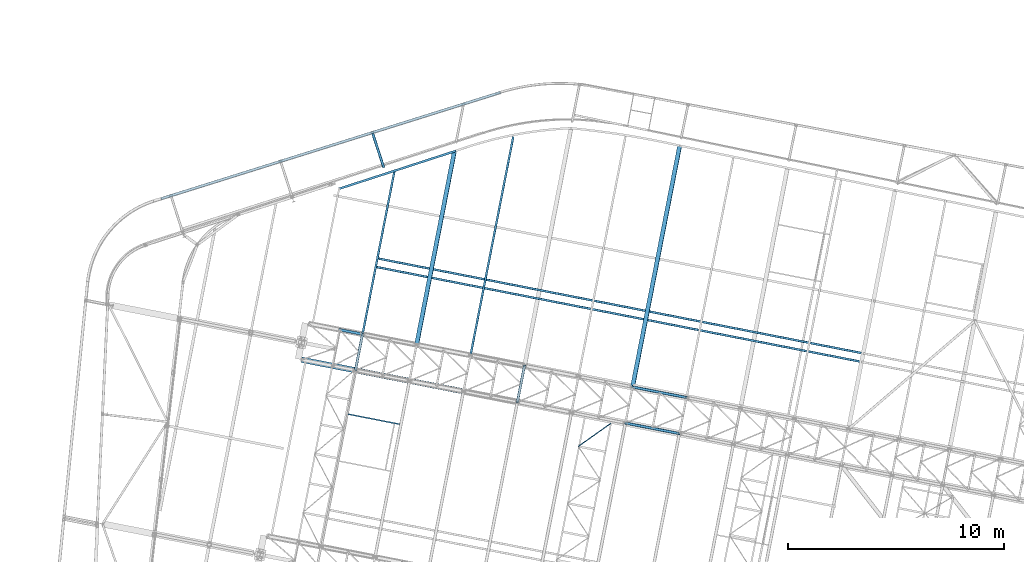
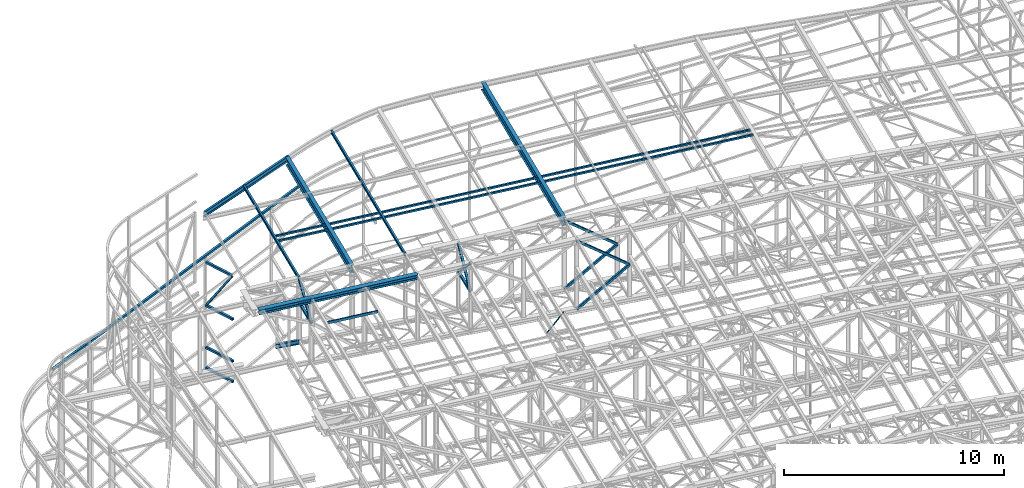
# One storey, part 85 of 215: 18 beams, 9 members, 27 elements without a shape of their own.
"""IFC2X3 building model written with IfcOpenShell, lengths in millimetres."""

from ifc_helpers import new_model, si_unit, frame, origin_with_axes, origin_2d_with_axis, place, context, subcontext, project, spatial, hollow_rectangle, i_section, u_section, extrude, clip, halfspace, material, type_object, element, aggregate, save


model = new_model("IFC2X3")

# Units and contexts
model_context = context("Model", 3, precision=1e-05, world=origin_with_axes())
body_context = subcontext(model_context, "Body", "Model", "MODEL_VIEW")
ifc_project = project(units=[si_unit("LENGTHUNIT", "METRE", prefix="MILLI"), si_unit("AREAUNIT", "SQUARE_METRE"), si_unit("VOLUMEUNIT", "CUBIC_METRE"), si_unit("MASSUNIT", "GRAM", prefix="KILO"), si_unit("TIMEUNIT", "SECOND"), si_unit("PLANEANGLEUNIT", "RADIAN"), si_unit("SOLIDANGLEUNIT", "STERADIAN"), si_unit("THERMODYNAMICTEMPERATUREUNIT", "DEGREE_CELSIUS"), si_unit("LUMINOUSINTENSITYUNIT", "LUMEN")], contexts=[model_context])

# Site, building, storey
site_placement = place(None, origin_with_axes())
site = spatial("IfcSite", under=ifc_project, at=site_placement, CompositionType="ELEMENT")
building_placement = place(site_placement, origin_with_axes())
building = spatial("IfcBuilding", under=site, at=building_placement, Name="Undefined", CompositionType="ELEMENT")
storey_placement = place(building_placement, origin_with_axes())
storey = spatial("IfcBuildingStorey", under=building, at=storey_placement, Name="Undefined", CompositionType="ELEMENT", Elevation=0.0)

# Assembly, beam
assembly_1_placement = place(storey_placement, origin_with_axes())
assembly_1 = element("IfcElementAssembly", 1, at=assembly_1_placement, inside=storey, Name="Steel Assembly", AssemblyPlace="NOTDEFINED", PredefinedType="RIGID_FRAME")
ifc_material_1 = material(Name="STEEL/S355JR")
beam_type_1 = type_object("IfcBeamType", Name="IPE240", PredefinedType="NOTDEFINED")
beam_1_placement = place(assembly_1_placement, frame((49720.9342823001, 53220.8282778538, 8620.00000002625), z_axis=(0.0, 0.0, 1.0), x_axis=(0.981422409205525, -0.19185946604018, 1.89999991602007e-08)))
beam_1 = element("IfcBeam", 2, at=beam_1_placement, type_object=beam_type_1, material=ifc_material_1, ObjectType="IPE240", context=body_context, shape_type="SweptSolid", body=[
    extrude(i_section(OverallWidth=120.0, OverallDepth=240.0, WebThickness=6.199999809, FlangeThickness=9.800000191, FilletRadius=15.0, at=origin_2d_with_axis()), frame((1125.93643654122, 0.0, 0.0), z_axis=(-1.0, 0.0, 0.0), x_axis=(-6.93889390390723e-18, -1.0, -3.46944695195361e-18)), (0.0, 0.0, 1.0), 1125.9),
])
aggregate(assembly_1, [beam_1])

assembly_2_placement = place(storey_placement, origin_with_axes())
assembly_2 = element("IfcElementAssembly", 3, at=assembly_2_placement, inside=storey, Name="Steel Assembly", AssemblyPlace="NOTDEFINED", PredefinedType="RIGID_FRAME")
ifc_material_2 = material(Name="STEEL/S275JR")
beam_type_2 = type_object("IfcBeamType", PredefinedType="NOTDEFINED")
beam_2_placement = place(assembly_2_placement, frame((57199.7178699806, 64183.9594944319, 8168.21947642145), z_axis=(-0.298921317164978, 0.954277761526672, 0.0), x_axis=(-0.949616807659648, -0.297461303893387, -0.0987152029646195)))
beam_2 = element("IfcBeam", 4, at=beam_2_placement, type_object=beam_type_2, material=ifc_material_2, Name="LISSE", context=body_context, shape_type="SweptSolid", body=[
    extrude(hollow_rectangle(XDim=120.0, YDim=120.0, WallThickness=4.0, InnerFilletRadius=4.0, OuterFilletRadius=8.0, at=origin_2d_with_axis()), frame((16520.13991497, -1.81898940354586e-12, 8.22106959654023e-12), z_axis=(-1.0, 0.0, 0.0), x_axis=(-6.93889390390723e-18, -1.0, -3.46944695195361e-18)), (0.0, 0.0, 1.0), 16520.1),
])
aggregate(assembly_2, [beam_2])

assembly_3_placement = place(storey_placement, origin_with_axes())
assembly_3 = element("IfcElementAssembly", 5, at=assembly_3_placement, inside=storey, Name="Steel Assembly", AssemblyPlace="NOTDEFINED", PredefinedType="RIGID_FRAME")
beam_type_3 = type_object("IfcBeamType", PredefinedType="NOTDEFINED")
beam_3_placement = place(assembly_3_placement, frame((50499.7937348464, 51336.3886035266, 10796.0000010378), z_axis=(0.981422364268518, -0.191859461052493, -0.000300197000082615), x_axis=(0.191859470081235, 0.981422408415534, 0.0)))
beam_3 = element("IfcBeam", 6, at=beam_3_placement, type_object=beam_type_3, material=ifc_material_2, context=body_context, shape_type="SweptSolid", body=[
    extrude(hollow_rectangle(XDim=120.0, YDim=120.0, WallThickness=5.0, InnerFilletRadius=5.0, OuterFilletRadius=10.0, at=origin_2d_with_axis()), frame((1699.99999941724, 1.81898940354586e-12, 0.0), z_axis=(-1.0, 0.0, 0.0), x_axis=(-6.93889390390723e-18, -1.0, -3.46944695195361e-18)), (0.0, 0.0, 1.0), 1700.0),
])
aggregate(assembly_3, [beam_3])

assembly_4_placement = place(storey_placement, origin_with_axes())
assembly_4 = element("IfcElementAssembly", 7, at=assembly_4_placement, inside=storey, Name="Steel Assembly", AssemblyPlace="NOTDEFINED", PredefinedType="RIGID_FRAME")
beam_4_placement = place(assembly_4_placement, frame((57988.3019099804, 49872.4511087156, 10796.0000010585), z_axis=(0.981422364268518, -0.191859461052493, -0.000300197000082615), x_axis=(0.191859470081235, 0.981422408415534, 0.0)))
beam_4 = element("IfcBeam", 8, at=beam_4_placement, type_object=beam_type_3, material=ifc_material_2, context=body_context, shape_type="SweptSolid", body=[
    extrude(hollow_rectangle(XDim=120.0, YDim=120.0, WallThickness=5.0, InnerFilletRadius=5.0, OuterFilletRadius=10.0, at=origin_2d_with_axis()), frame((1699.99999941724, 1.81898940354586e-12, 0.0), z_axis=(-1.0, 0.0, 0.0), x_axis=(-6.93889390390723e-18, -1.0, -3.46944695195361e-18)), (0.0, 0.0, 1.0), 1700.0),
])
aggregate(assembly_4, [beam_4])

assembly_5_placement = place(storey_placement, origin_with_axes())
assembly_5 = element("IfcElementAssembly", 9, at=assembly_5_placement, inside=storey, Name="Steel Assembly", AssemblyPlace="NOTDEFINED", PredefinedType="RIGID_FRAME")
beam_5_placement = place(assembly_5_placement, frame((51302.0859467722, 62273.9068351833, 4846.36704267052), z_axis=(-0.951354549825319, -0.308098231943425, 0.0), x_axis=(0.30809823194343, -0.951354549825318, -1.99999977269e-09)))
beam_5 = element("IfcBeam", 10, at=beam_5_placement, type_object=beam_type_3, material=ifc_material_2, context=body_context, shape_type="SweptSolid", body=[
    extrude(hollow_rectangle(XDim=120.0, YDim=120.0, WallThickness=5.0, InnerFilletRadius=5.0, OuterFilletRadius=10.0, at=origin_2d_with_axis()), frame((1647.01960404761, -9.09494701091737e-13, 3.50813501506244e-29), z_axis=(-1.0, 0.0, 0.0), x_axis=(-6.93889390390723e-18, -1.0, -3.46944695195361e-18)), (0.0, 0.0, 1.0), 1647.0),
])
aggregate(assembly_5, [beam_5])

assembly_6_placement = place(storey_placement, origin_with_axes())
assembly_6 = element("IfcElementAssembly", 11, at=assembly_6_placement, inside=storey, Name="Steel Assembly", AssemblyPlace="NOTDEFINED", PredefinedType="RIGID_FRAME")
beam_6_placement = place(assembly_6_placement, frame((51302.0851895902, 62273.9066010816, 1388.24312905924), z_axis=(-0.951354549825319, -0.308098231943425, 0.0), x_axis=(0.30809823194343, -0.951354549825318, -1.99999977269e-09)))
beam_6 = element("IfcBeam", 12, at=beam_6_placement, type_object=beam_type_3, material=ifc_material_2, context=body_context, shape_type="SweptSolid", body=[
    extrude(hollow_rectangle(XDim=120.0, YDim=120.0, WallThickness=5.0, InnerFilletRadius=5.0, OuterFilletRadius=10.0, at=origin_2d_with_axis()), frame((1647.01960404761, -9.09494701091737e-13, 3.50813501506244e-29), z_axis=(-1.0, 0.0, 0.0), x_axis=(-6.93889390390723e-18, -1.0, -3.46944695195361e-18)), (0.0, 0.0, 1.0), 1647.0),
])
aggregate(assembly_6, [beam_6])

assembly_7_placement = place(storey_placement, origin_with_axes())
assembly_7 = element("IfcElementAssembly", 13, at=assembly_7_placement, inside=storey, Name="Steel Assembly", AssemblyPlace="NOTDEFINED", PredefinedType="RIGID_FRAME")
beam_7_placement = place(assembly_7_placement, frame((51302.0859461039, 62273.9068372421, 2522.06977230949), z_axis=(-0.951354549825319, -0.308098231943425, 0.0), x_axis=(0.30809823194343, -0.951354549825318, -1.99999977269e-09)))
beam_7 = element("IfcBeam", 14, at=beam_7_placement, type_object=beam_type_3, material=ifc_material_2, context=body_context, shape_type="SweptSolid", body=[
    extrude(hollow_rectangle(XDim=120.0, YDim=120.0, WallThickness=5.0, InnerFilletRadius=5.0, OuterFilletRadius=10.0, at=origin_2d_with_axis()), frame((1647.01960404761, -9.09494701091737e-13, 3.50813501506244e-29), z_axis=(-1.0, 0.0, 0.0), x_axis=(-6.93889390390723e-18, -1.0, -3.46944695195361e-18)), (0.0, 0.0, 1.0), 1647.0),
])
aggregate(assembly_7, [beam_7])

assembly_8_placement = place(storey_placement, origin_with_axes())
assembly_8 = element("IfcElementAssembly", 15, at=assembly_8_placement, inside=storey, Name="Steel Assembly", AssemblyPlace="NOTDEFINED", PredefinedType="RIGID_FRAME")
beam_8_placement = place(assembly_8_placement, frame((51302.0859431698, 62273.9068315122, 7238.97316136958), z_axis=(-0.951355977985299, -0.308093821995242, 0.0), x_axis=(0.30809382199524, -0.951355977985299, -1.9999999219307e-09)))
beam_8 = element("IfcBeam", 16, at=beam_8_placement, type_object=beam_type_3, material=ifc_material_2, context=body_context, shape_type="SweptSolid", body=[
    extrude(hollow_rectangle(XDim=120.0, YDim=120.0, WallThickness=5.0, InnerFilletRadius=5.0, OuterFilletRadius=10.0, at=origin_2d_with_axis()), frame((1588.37298675164, -9.09494701772928e-13, -1.31387128885739e-29), z_axis=(-1.0, 0.0, 0.0), x_axis=(-6.93889390390723e-18, -1.0, -3.46944695195361e-18)), (0.0, 0.0, 1.0), 1588.4),
])
aggregate(assembly_8, [beam_8])

assembly_9_placement = place(storey_placement, origin_with_axes())
assembly_9 = element("IfcElementAssembly", 17, at=assembly_9_placement, inside=storey, Name="Steel Assembly", AssemblyPlace="NOTDEFINED", PredefinedType="RIGID_FRAME")
beam_type_4 = type_object("IfcBeamType", PredefinedType="NOTDEFINED")
beam_9_placement = place(assembly_9_placement, frame((51515.0832729694, 56510.0172378365, 12080.2742025674), z_axis=(0.0304072880144601, -0.0059443590028274, -0.99951991547525), x_axis=(0.980943093982696, -0.191809039996616, 0.0309828749994535)))
beam_9 = element("IfcBeam", 18, at=beam_9_placement, type_object=beam_type_4, material=ifc_material_2, context=body_context, shape_type="SweptSolid", body=[
    extrude(hollow_rectangle(XDim=100.0, YDim=100.0, WallThickness=5.0, InnerFilletRadius=5.0, OuterFilletRadius=10.0, at=origin_2d_with_axis()), frame((22897.097980104, -8.21343149231186e-12, 3.71741907388737e-12), z_axis=(-1.0, 0.0, 0.0), x_axis=(-6.93889390390723e-18, -1.0, -3.46944695195361e-18)), (0.0, 0.0, 1.0), 22897.1),
])
aggregate(assembly_9, [beam_9])

assembly_10_placement = place(storey_placement, origin_with_axes())
assembly_10 = element("IfcElementAssembly", 19, at=assembly_10_placement, inside=storey, Name="Steel Assembly", AssemblyPlace="NOTDEFINED", PredefinedType="RIGID_FRAME")
beam_10_placement = place(assembly_10_placement, frame((51438.3227735584, 56117.451541789, 12080.2742014752), z_axis=(0.0304072880144601, -0.0059443590028274, -0.99951991547525), x_axis=(0.980943093982696, -0.191809039996616, 0.0309828749994535)))
beam_10 = element("IfcBeam", 20, at=beam_10_placement, type_object=beam_type_4, material=ifc_material_2, context=body_context, shape_type="SweptSolid", body=[
    extrude(hollow_rectangle(XDim=100.0, YDim=100.0, WallThickness=5.0, InnerFilletRadius=5.0, OuterFilletRadius=10.0, at=origin_2d_with_axis()), frame((22896.595182409, -4.8084209346404e-14, 1.73955088118013e-12), z_axis=(-1.0, 0.0, 0.0), x_axis=(-6.93889390390723e-18, -1.0, -3.46944695195361e-18)), (0.0, 0.0, 1.0), 22896.6),
])
aggregate(assembly_10, [beam_10])

assembly_11_placement = place(storey_placement, origin_with_axes())
assembly_11 = element("IfcElementAssembly", 21, at=assembly_11_placement, inside=storey, Name="Steel Assembly", AssemblyPlace="NOTDEFINED", PredefinedType="RIGID_FRAME")
beam_type_5 = type_object("IfcBeamType", PredefinedType="NOTDEFINED")
beam_11_placement = place(assembly_11_placement, frame((62310.4731593612, 48884.9491979367, 8745.0), z_axis=(0.0, 0.0, -1.0), x_axis=(-0.815674648101608, -0.578510906072062, 0.0)))
beam_11 = element("IfcBeam", 22, at=beam_11_placement, type_object=beam_type_5, material=ifc_material_2, context=body_context, shape_type="SweptSolid", body=[
    extrude(hollow_rectangle(XDim=50.0, YDim=50.0, WallThickness=3.0, InnerFilletRadius=3.0, OuterFilletRadius=6.0, at=origin_2d_with_axis()), frame((1847.1566108947, 0.0, 0.0), z_axis=(-1.0, 0.0, 0.0), x_axis=(-6.93889390390723e-18, -1.0, -3.46944695195361e-18)), (0.0, 0.0, 1.0), 1847.2),
])
aggregate(assembly_11, [beam_11])

assembly_12_placement = place(storey_placement, origin_with_axes())
assembly_12 = element("IfcElementAssembly", 23, at=assembly_12_placement, inside=storey, Name="Steel Assembly", AssemblyPlace="NOTDEFINED", PredefinedType="RIGID_FRAME")
ifc_material_3 = material(Name="STEEL/S235JR")
beam_type_6 = type_object("IfcBeamType", Name="UPN140", PredefinedType="NOTDEFINED")
beam_12_placement = place(assembly_12_placement, frame((52544.7314450407, 48841.1946423536, 12217.2315488064), z_axis=(-0.0304080349967745, 0.00594450299936818, 0.999519891893966), x_axis=(-0.980947279001733, 0.191787511000338, -0.0309836480000548)))
beam_12 = element("IfcBeam", 24, at=beam_12_placement, type_object=beam_type_6, material=ifc_material_3, ObjectType="UPN140", context=body_context, shape_type="SweptSolid", body=[
    extrude(u_section(Depth=140.0, FlangeWidth=60.0, WebThickness=7.0, FlangeThickness=10.0, FilletRadius=10.0, EdgeRadius=5.0, FlangeSlope=0.0798299857122373, at=origin_2d_with_axis()), frame((2424.69780127148, -3.7379625959944e-14, 0.0), z_axis=(-1.0, 0.0, 0.0), x_axis=(-6.93889390390723e-18, -1.0, -3.46944695195361e-18)), (0.0, 0.0, 1.0), 2424.7),
])
aggregate(assembly_12, [beam_12])

assembly_13_placement = place(storey_placement, origin_with_axes())
assembly_13 = element("IfcElementAssembly", 25, at=assembly_13_placement, inside=storey, Name="Steel Assembly", AssemblyPlace="NOTDEFINED", PredefinedType="RIGID_FRAME")
beam_type_7 = type_object("IfcBeamType", Name="IPE180", PredefinedType="NOTDEFINED")
beam_13_placement = place(assembly_13_placement, frame((50828.6906783328, 53004.2722118024, 12120.2550178745), z_axis=(-0.0304080349967745, 0.00594450299936818, 0.999519891893966), x_axis=(0.191838682977215, 0.981426471883435, 9.99999920550121e-10)))
beam_13 = element("IfcBeam", 26, at=beam_13_placement, type_object=beam_type_7, material=ifc_material_2, ObjectType="IPE180", context=body_context, shape_type="SweptSolid", body=[
    extrude(i_section(OverallWidth=91.0, OverallDepth=180.0, WebThickness=5.300000191, FlangeThickness=8.0, FilletRadius=9.0, at=origin_2d_with_axis()), frame((7695.10977276959, -7.28717373048567e-12, 5.83931719652145e-16), z_axis=(-1.0, 0.0, 0.0), x_axis=(-6.93889390390723e-18, -1.0, -3.46944695195361e-18)), (0.0, 0.0, 1.0), 7695.1),
])
aggregate(assembly_13, [beam_13])

assembly_14_placement = place(storey_placement, origin_with_axes())
assembly_14 = element("IfcElementAssembly", 27, at=assembly_14_placement, inside=storey, Name="Steel Assembly", AssemblyPlace="NOTDEFINED", PredefinedType="RIGID_FRAME")
beam_14_placement = place(assembly_14_placement, frame((55821.1394941475, 52028.2922302568, 12277.9430005175), z_axis=(-0.0304080349967745, 0.00594450299936818, 0.999519891893966), x_axis=(0.191843454053324, 0.981425539272792, 9.99999990656702e-10)))
beam_14 = element("IfcBeam", 28, at=beam_14_placement, type_object=beam_type_7, material=ifc_material_2, ObjectType="IPE180", context=body_context, shape_type="SweptSolid", body=[
    extrude(i_section(OverallWidth=91.0, OverallDepth=180.0, WebThickness=5.300000191, FlangeThickness=8.0, FilletRadius=9.0, at=origin_2d_with_axis()), frame((10300.7479135875, -3.66799750671303e-14, -1.08531087631037e-15), z_axis=(-1.0, 0.0, 0.0), x_axis=(-6.93889390390723e-18, -1.0, -3.46944695195361e-18)), (0.0, 0.0, 1.0), 10300.7),
])
aggregate(assembly_14, [beam_14])

# Assembly, member
assembly_15_placement = place(storey_placement, origin_with_axes())
assembly_15 = element("IfcElementAssembly", 29, at=assembly_15_placement, inside=storey, Name="Steel Assembly", AssemblyPlace="NOTDEFINED", PredefinedType="RIGID_FRAME")
member_type_1 = type_object("IfcMemberType", PredefinedType="NOTDEFINED")
member_1_placement = place(assembly_15_placement, frame((51791.453886931, 60762.7909402812, 7198.97315823117), z_axis=(-0.951263377201435, -0.308379548065297, -0.000203790000042725), x_axis=(-0.17239702104213, 0.532343576130095, -0.828788021202539)))
member_1 = element("IfcMember", 30, at=member_1_placement, type_object=member_type_1, material=ifc_material_2, context=body_context, shape_type="SweptSolid", body=[
    extrude(hollow_rectangle(XDim=100.0, YDim=100.0, WallThickness=5.0, InnerFilletRadius=5.0, OuterFilletRadius=10.0, at=origin_2d_with_axis()), frame((2838.61018117218, -7.27595761418343e-12, 1.44370427884513e-11), z_axis=(-1.0, 0.0, 0.0), x_axis=(-6.93889390390723e-18, -1.0, -3.46944695195361e-18)), (0.0, 0.0, 1.0), 2838.6),
])
aggregate(assembly_15, [member_1])

assembly_16_placement = place(storey_placement, origin_with_axes())
assembly_16 = element("IfcElementAssembly", 31, at=assembly_16_placement, inside=storey, Name="Steel Assembly", AssemblyPlace="NOTDEFINED", PredefinedType="RIGID_FRAME")
member_type_2 = type_object("IfcMemberType", PredefinedType="NOTDEFINED")
member_2_placement = place(assembly_16_placement, frame((50825.9548335312, 53004.8066973449, 10796.0000010455), z_axis=(0.981457773618154, -0.191678330925429, 0.000236765999907874), x_axis=(-0.15135681799229, -0.774238415960567, 0.614529078968702)))
member_2 = element("IfcMember", 32, at=member_2_placement, type_object=member_type_2, material=ifc_material_2, context=body_context, shape_type="SweptSolid", body=[
    extrude(hollow_rectangle(XDim=120.0, YDim=120.0, WallThickness=5.0, InnerFilletRadius=5.0, OuterFilletRadius=10.0, at=origin_2d_with_axis()), frame((2154.91514201782, 7.15633579384435e-12, 2.72186368544976e-14), z_axis=(-1.0, 0.0, 0.0), x_axis=(-6.93889390390723e-18, -1.0, -3.46944695195361e-18)), (0.0, 0.0, 1.0), 2154.9),
])
aggregate(assembly_16, [member_2])

assembly_17_placement = place(storey_placement, origin_with_axes())
assembly_17 = element("IfcElementAssembly", 33, at=assembly_17_placement, inside=storey, Name="Steel Assembly", AssemblyPlace="NOTDEFINED", PredefinedType="RIGID_FRAME")
member_3_placement = place(assembly_17_placement, frame((50499.7937348464, 51336.3886035266, 10796.0000010378), z_axis=(0.981457773617921, -0.191678330925384, -0.000236766999908156), x_axis=(0.151356816942679, 0.774238418706794, 0.614529075767276)))
member_3 = element("IfcMember", 34, at=member_3_placement, type_object=member_type_2, material=ifc_material_2, context=body_context, shape_type="SweptSolid", body=[
    extrude(hollow_rectangle(XDim=120.0, YDim=120.0, WallThickness=5.0, InnerFilletRadius=5.0, OuterFilletRadius=10.0, at=origin_2d_with_axis()), frame((2154.91514201782, 7.15633579384435e-12, 2.72186368544976e-14), z_axis=(-1.0, 0.0, 0.0), x_axis=(-6.93889390390723e-18, -1.0, -3.46944695195361e-18)), (0.0, 0.0, 1.0), 2154.9),
])
aggregate(assembly_17, [member_3])

assembly_18_placement = place(storey_placement, origin_with_axes())
assembly_18 = element("IfcElementAssembly", 35, at=assembly_18_placement, inside=storey, Name="Steel Assembly", AssemblyPlace="NOTDEFINED", PredefinedType="RIGID_FRAME")
member_4_placement = place(assembly_18_placement, frame((58314.4630086735, 51540.8692025378, 10796.0000010567), z_axis=(0.981461316285517, -0.191660209055757, 0.000221133000063429), x_axis=(-0.1413283100442, -0.722939399226104, 0.676302398211518)))
member_4 = element("IfcMember", 36, at=member_4_placement, type_object=member_type_2, material=ifc_material_2, context=body_context, shape_type="SweptSolid", body=[
    extrude(hollow_rectangle(XDim=120.0, YDim=120.0, WallThickness=5.0, InnerFilletRadius=5.0, OuterFilletRadius=10.0, at=origin_2d_with_axis()), frame((2307.82564529445, -1.28110058411315e-13, 8.31339197405457e-14), z_axis=(-1.0, 0.0, 0.0), x_axis=(-6.93889390390723e-18, -1.0, -3.46944695195361e-18)), (0.0, 0.0, 1.0), 2307.8),
])
aggregate(assembly_18, [member_4])

assembly_19_placement = place(storey_placement, origin_with_axes())
assembly_19 = element("IfcElementAssembly", 37, at=assembly_19_placement, inside=storey, Name="Steel Assembly", AssemblyPlace="NOTDEFINED", PredefinedType="RIGID_FRAME")
member_5_placement = place(assembly_19_placement, frame((57988.3019099804, 49872.4511087156, 10796.0000010585), z_axis=(0.981461316285734, -0.1916602090558, -0.000221132000064958), x_axis=(0.141328309922255, 0.722939402602315, 0.67630239462797)))
member_5 = element("IfcMember", 38, at=member_5_placement, type_object=member_type_2, material=ifc_material_2, context=body_context, shape_type="SweptSolid", body=[
    extrude(hollow_rectangle(XDim=120.0, YDim=120.0, WallThickness=5.0, InnerFilletRadius=5.0, OuterFilletRadius=10.0, at=origin_2d_with_axis()), frame((2307.82564529445, -1.28110058411315e-13, 8.31339197405457e-14), z_axis=(-1.0, 0.0, 0.0), x_axis=(-6.93889390390723e-18, -1.0, -3.46944695195361e-18)), (0.0, 0.0, 1.0), 2307.8),
])
aggregate(assembly_19, [member_5])

assembly_20_placement = place(storey_placement, origin_with_axes())
assembly_20 = element("IfcElementAssembly", 39, at=assembly_20_placement, inside=storey, Name="Steel Assembly", AssemblyPlace="NOTDEFINED", PredefinedType="RIGID_FRAME")
member_6_placement = place(assembly_20_placement, frame((63307.0759588878, 50564.857056495, 8655.00000165951), z_axis=(0.587493472692391, -0.114849807939864, -0.801037415580578), x_axis=(0.786156070230782, -0.153686611045116, 0.598614282175727)))
member_6 = element("IfcMember", 40, at=member_6_placement, type_object=member_type_2, material=ifc_material_2, context=body_context, shape_type="SweptSolid", body=[
    extrude(hollow_rectangle(XDim=120.0, YDim=120.0, WallThickness=5.0, InnerFilletRadius=5.0, OuterFilletRadius=10.0, at=origin_2d_with_axis()), frame((3169.02675432624, -2.43384340210519e-14, 0.0), z_axis=(-1.0, 0.0, 0.0), x_axis=(-6.93889390390723e-18, -1.0, -3.46944695195361e-18)), (0.0, 0.0, 1.0), 3169.0),
])
aggregate(assembly_20, [member_6])

assembly_21_placement = place(storey_placement, origin_with_axes())
assembly_21 = element("IfcElementAssembly", 41, at=assembly_21_placement, inside=storey, Name="Steel Assembly", AssemblyPlace="NOTDEFINED", PredefinedType="RIGID_FRAME")
member_7_placement = place(assembly_21_placement, frame((62980.9148919242, 48896.4389558326, 8655.00000165951), z_axis=(0.587493472692391, -0.114849807939864, -0.801037415580578), x_axis=(0.786156070230782, -0.153686611045116, 0.598614282175727)))
member_7 = element("IfcMember", 42, at=member_7_placement, type_object=member_type_2, material=ifc_material_2, context=body_context, shape_type="SweptSolid", body=[
    extrude(hollow_rectangle(XDim=120.0, YDim=120.0, WallThickness=5.0, InnerFilletRadius=5.0, OuterFilletRadius=10.0, at=origin_2d_with_axis()), frame((3169.02675432624, -2.43384340210519e-14, 0.0), z_axis=(-1.0, 0.0, 0.0), x_axis=(-6.93889390390723e-18, -1.0, -3.46944695195361e-18)), (0.0, 0.0, 1.0), 3169.0),
])
aggregate(assembly_21, [member_7])

assembly_22_placement = place(storey_placement, origin_with_axes())
assembly_22 = element("IfcElementAssembly", 43, at=assembly_22_placement, inside=storey, Name="Steel Assembly", AssemblyPlace="NOTDEFINED", PredefinedType="RIGID_FRAME")
member_8_placement = place(assembly_22_placement, frame((63311.7892047768, 50563.9356572793, 12449.5061705353), z_axis=(-0.5871579940314, 0.114784234006137, -0.80129274904285), x_axis=(0.786406660116399, -0.153735599022755, -0.598272455088553)))
member_8 = element("IfcMember", 44, at=member_8_placement, type_object=member_type_2, material=ifc_material_2, context=body_context, shape_type="SweptSolid", body=[
    extrude(hollow_rectangle(XDim=120.0, YDim=120.0, WallThickness=5.0, InnerFilletRadius=5.0, OuterFilletRadius=10.0, at=origin_2d_with_axis()), frame((3165.45158595242, -1.49800009052741e-13, -1.7571786170303e-13), z_axis=(-1.0, 0.0, 0.0), x_axis=(-6.93889390390723e-18, -1.0, -3.46944695195361e-18)), (0.0, 0.0, 1.0), 3165.5),
])
aggregate(assembly_22, [member_8])

assembly_23_placement = place(storey_placement, origin_with_axes())
assembly_23 = element("IfcElementAssembly", 45, at=assembly_23_placement, inside=storey, Name="Steel Assembly", AssemblyPlace="NOTDEFINED", PredefinedType="RIGID_FRAME")
member_9_placement = place(assembly_23_placement, frame((62985.6281378301, 48895.5175566136, 12449.5061705353), z_axis=(-0.5871579940314, 0.114784234006137, -0.80129274904285), x_axis=(0.786406660116399, -0.153735599022755, -0.598272455088553)))
member_9 = element("IfcMember", 46, at=member_9_placement, type_object=member_type_2, material=ifc_material_2, context=body_context, shape_type="SweptSolid", body=[
    extrude(hollow_rectangle(XDim=120.0, YDim=120.0, WallThickness=5.0, InnerFilletRadius=5.0, OuterFilletRadius=10.0, at=origin_2d_with_axis()), frame((3165.45158595242, -1.49800009052741e-13, -1.7571786170303e-13), z_axis=(-1.0, 0.0, 0.0), x_axis=(-6.93889390390723e-18, -1.0, -3.46944695195361e-18)), (0.0, 0.0, 1.0), 3165.5),
])
aggregate(assembly_23, [member_9])

# Assembly, beam
assembly_24_placement = place(storey_placement, origin_with_axes())
assembly_24 = element("IfcElementAssembly", 47, at=assembly_24_placement, inside=storey, Name="Steel Assembly", AssemblyPlace="NOTDEFINED", PredefinedType="RIGID_FRAME")
beam_type_8 = type_object("IfcBeamType", Name="UPE300", PredefinedType="NOTDEFINED")
beam_15_placement = place(assembly_24_placement, frame((55152.7240324316, 61484.0961996211, 12136.0558949384), z_axis=(0.025173161988543, 0.00816309799628229, -0.999649776545067), x_axis=(-0.950841252477105, -0.308545925830322, -0.0264636399854468)))
beam_15 = element("IfcBeam", 48, at=beam_15_placement, type_object=beam_type_8, material=ifc_material_2, Name="POUTRE", ObjectType="UPE300", context=body_context, shape_type="SweptSolid", body=[
    extrude(u_section(Depth=300.0, FlangeWidth=100.0, WebThickness=9.5, FlangeThickness=15.0, FilletRadius=15.0, at=origin_2d_with_axis()), frame((5702.1822278154, 8.24459546962555e-14, 0.0), z_axis=(-1.0, 0.0, 0.0), x_axis=(-6.93889390390723e-18, -1.0, -3.46944695195361e-18)), (0.0, 0.0, 1.0), 5702.2),
])
aggregate(assembly_24, [beam_15])

assembly_25_placement = place(storey_placement, origin_with_axes())
assembly_25 = element("IfcElementAssembly", 49, at=assembly_25_placement, inside=storey, Name="Steel Assembly", AssemblyPlace="NOTDEFINED", PredefinedType="RIGID_FRAME")
beam_type_9 = type_object("IfcBeamType", Name="IPE450", PredefinedType="NOTDEFINED")
beam_16_placement = place(assembly_25_placement, frame((53329.0194769384, 52515.4794784802, 12062.0713978446), z_axis=(-0.0304080349967745, 0.00594450299936818, 0.999519891893966), x_axis=(0.191841588006851, 0.981425904035047, 0.0)))
beam_16 = element("IfcBeam", 50, at=beam_16_placement, type_object=beam_type_9, material=ifc_material_2, Name="POUTRE", ObjectType="IPE450", context=body_context, shape_type="SweptSolid", body=[
    extrude(i_section(OverallWidth=190.0, OverallDepth=450.0, WebThickness=9.399999619, FlangeThickness=14.60000038, FilletRadius=21.0, at=origin_2d_with_axis()), frame((9082.29376128644, 0.0, -1.81111176944415e-12), z_axis=(-1.0, 0.0, 0.0), x_axis=(-6.93889390390723e-18, -1.0, -3.46944695195361e-18)), (0.0, 0.0, 1.0), 9082.3),
])
aggregate(assembly_25, [beam_16])

assembly_26_placement = place(storey_placement, origin_with_axes())
assembly_26 = element("IfcElementAssembly", 51, at=assembly_26_placement, inside=storey, Name="Steel Assembly", AssemblyPlace="NOTDEFINED", PredefinedType="RIGID_FRAME")
beam_17_placement = place(assembly_26_placement, frame((63313.9158933653, 50563.5200117125, 12377.4473194819), z_axis=(-0.0304080349967745, 0.00594450299936818, 0.999519891893966), x_axis=(0.191845211931802, 0.981425195651121, 9.9999994476379e-10)))
beam_17 = element("IfcBeam", 52, at=beam_17_placement, type_object=beam_type_9, material=ifc_material_2, Name="POUTRE", ObjectType="IPE450", context=body_context, shape_type="Clipping", body=[
    clip(extrude(i_section(OverallWidth=190.0, OverallDepth=450.0, WebThickness=9.399999619, FlangeThickness=14.60000038, FilletRadius=21.0, at=origin_2d_with_axis()), frame((11499.0918606654, 0.0, 1.79904165894275e-12), z_axis=(-1.0, 0.0, 0.0), x_axis=(-6.93889390390723e-18, -1.0, -3.46944695195361e-18)), (0.0, 0.0, 1.0), 11499.1), halfspace(frame((11422.6836583368, 543.136665988997, -12366.5562527647), z_axis=(-0.999847919008814, 0.0174312043367108, 0.00054034166664944), x_axis=(4.11426299251616e-10, -0.0309836361466733, 0.999519891893669)), True)),
])
aggregate(assembly_26, [beam_17])

assembly_27_placement = place(storey_placement, origin_with_axes())
assembly_27 = element("IfcElementAssembly", 53, at=assembly_27_placement, inside=storey, Name="Steel Assembly", AssemblyPlace="NOTDEFINED", PredefinedType="RIGID_FRAME")
beam_type_10 = type_object("IfcBeamType", Name="HEA260", PredefinedType="NOTDEFINED")
beam_18_placement = place(assembly_27_placement, frame((48007.3693683801, 51823.6354286115, 12006.4278258793), z_axis=(-0.0304080349967745, 0.00594450299936818, 0.999519891893966), x_axis=(0.980951223231219, -0.191767338045201, 0.0309836360073031)))
beam_18 = element("IfcBeam", 54, at=beam_18_placement, type_object=beam_type_10, material=ifc_material_1, Name="SUP", ObjectType="HEA260", context=body_context, shape_type="SweptSolid", body=[
    extrude(i_section(OverallWidth=260.0, OverallDepth=250.0, WebThickness=7.5, FlangeThickness=12.5, FilletRadius=24.0, at=origin_2d_with_axis()), frame((7634.09340299227, -5.54373729838705e-14, -2.64860820879407e-14), z_axis=(-1.0, 0.0, 0.0), x_axis=(-6.93889390390723e-18, -1.0, -3.46944695195361e-18)), (0.0, 0.0, 1.0), 7634.1),
])
aggregate(assembly_27, [beam_18])

save(model, "model.ifc")
